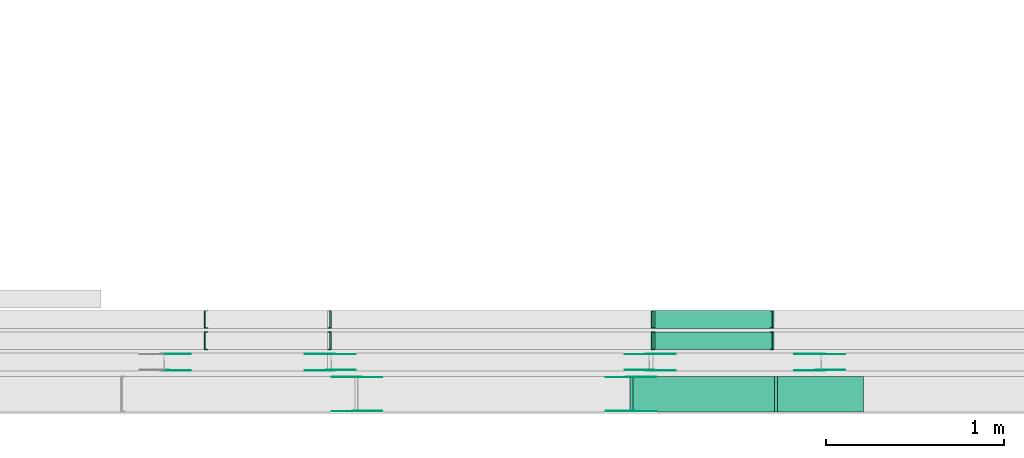
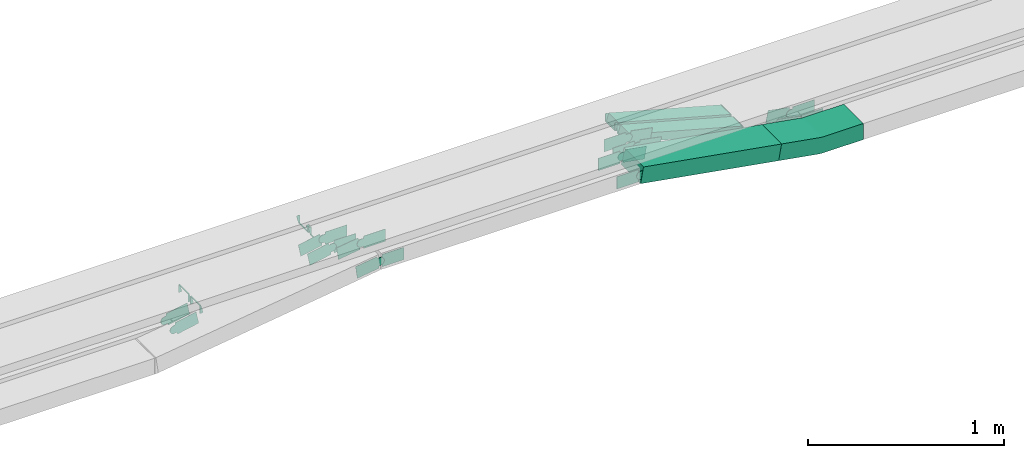
# One storey, part 8 of 28: 31 flow fittings, 3 flow segments.
"""IFC2X3 building model written with IfcOpenShell, lengths in millimetres."""

from ifc_helpers import new_model, entity, si_unit, converted_unit, derived_unit, direction, frame, frame_2d, origin, origin_2d_with_axis, place, context, subcontext, project, spatial, polyline, circle_curve, parameter, trimmed, segment, composite_curve, rectangle, outline, extrude, faceted_brep, source, transform, mapped, material, type_object, type_shapes, element, save


model = new_model("IFC2X3")

# Units and contexts
model_context = context("Model", 3, precision=0.01, world=origin(), true_north=direction((6.12303176911189e-17, 1.0)))
body_context = subcontext(model_context, "Body", "Model", "MODEL_VIEW")
ifc_project = project(units=[si_unit("LENGTHUNIT", "METRE", prefix="MILLI"), si_unit("AREAUNIT", "SQUARE_METRE"), si_unit("VOLUMEUNIT", "CUBIC_METRE"), converted_unit("PLANEANGLEUNIT", "DEGREE", entity("IfcRatioMeasure", 0.0174532925199433), si_unit("PLANEANGLEUNIT", "RADIAN"), dimensions=[0, 0, 0, 0, 0, 0, 0]), si_unit("MASSUNIT", "GRAM", prefix="KILO"), derived_unit("MASSDENSITYUNIT", [(si_unit("MASSUNIT", "GRAM", prefix="KILO"), 1), (si_unit("LENGTHUNIT", "METRE"), -3)]), derived_unit("MOMENTOFINERTIAUNIT", [(si_unit("LENGTHUNIT", "METRE"), 4)]), si_unit("TIMEUNIT", "SECOND"), si_unit("FREQUENCYUNIT", "HERTZ"), si_unit("THERMODYNAMICTEMPERATUREUNIT", "DEGREE_CELSIUS"), derived_unit("THERMALTRANSMITTANCEUNIT", [(si_unit("MASSUNIT", "GRAM", prefix="KILO"), 1), (si_unit("THERMODYNAMICTEMPERATUREUNIT", "KELVIN"), -1), (si_unit("TIMEUNIT", "SECOND"), -3)]), derived_unit("VOLUMETRICFLOWRATEUNIT", [(si_unit("LENGTHUNIT", "METRE"), 3), (si_unit("TIMEUNIT", "SECOND"), -1)]), derived_unit("MASSFLOWRATEUNIT", [(si_unit("MASSUNIT", "GRAM", prefix="KILO"), 1), (si_unit("TIMEUNIT", "SECOND"), -1)]), derived_unit("ROTATIONALFREQUENCYUNIT", [(si_unit("TIMEUNIT", "SECOND"), -1)]), si_unit("ELECTRICCURRENTUNIT", "AMPERE"), si_unit("ELECTRICVOLTAGEUNIT", "VOLT"), si_unit("POWERUNIT", "WATT"), si_unit("FORCEUNIT", "NEWTON", prefix="KILO"), si_unit("ILLUMINANCEUNIT", "LUX"), si_unit("LUMINOUSFLUXUNIT", "LUMEN"), si_unit("LUMINOUSINTENSITYUNIT", "CANDELA"), derived_unit("USERDEFINED", [(si_unit("MASSUNIT", "GRAM", prefix="KILO"), -1), (si_unit("LENGTHUNIT", "METRE"), -2), (si_unit("TIMEUNIT", "SECOND"), 3), (si_unit("LUMINOUSFLUXUNIT", "LUMEN"), 1)]), derived_unit("LINEARVELOCITYUNIT", [(si_unit("LENGTHUNIT", "METRE"), 1), (si_unit("TIMEUNIT", "SECOND"), -1)]), si_unit("PRESSUREUNIT", "PASCAL"), derived_unit("USERDEFINED", [(si_unit("LENGTHUNIT", "METRE"), -2), (si_unit("MASSUNIT", "GRAM", prefix="KILO"), 1), (si_unit("TIMEUNIT", "SECOND"), -2)]), derived_unit("LINEARFORCEUNIT", [(si_unit("MASSUNIT", "GRAM", prefix="KILO"), 1), (si_unit("LENGTHUNIT", "METRE"), 1), (si_unit("TIMEUNIT", "SECOND"), -2), (si_unit("LENGTHUNIT", "METRE"), -1)]), derived_unit("PLANARFORCEUNIT", [(si_unit("MASSUNIT", "GRAM", prefix="KILO"), 1), (si_unit("LENGTHUNIT", "METRE"), 1), (si_unit("TIMEUNIT", "SECOND"), -2), (si_unit("LENGTHUNIT", "METRE"), -2)])], contexts=[model_context])

# Site, building, storey
site_placement = place(None, origin())
site = spatial("IfcSite", under=ifc_project, at=site_placement, CompositionType="ELEMENT")
building_placement = place(site_placement, origin())
building = spatial("IfcBuilding", under=site, at=building_placement, CompositionType="ELEMENT")
storey_placement = place(building_placement, frame((0.0, 0.0, 15900.0)))
storey = spatial("IfcBuildingStorey", under=building, at=storey_placement, CompositionType="ELEMENT", Elevation=15900.0)

# Flow segments
cable_carrier_segment_type = type_object("IfcCableCarrierSegmentType", PredefinedType="CABLETRAYSEGMENT")
flow_segment_1_placement = place(storey_placement, frame((26335.74, 8695.5, 2502.67)))
element("IfcFlowSegment", 1, at=flow_segment_1_placement, inside=storey, type_object=cable_carrier_segment_type, context=body_context, shape_type="SweptSolid", body=[
    extrude(rectangle(XDim=50.0000000000012, YDim=99.9999999999989, at=frame_2d((0.0, 0.0), x_axis=(0.0, 1.0))), frame((6.61, 50.0, 205.56), z_axis=(0.964454896083655, 0.0, -0.264247523016331), x_axis=(0.0, 1.0, 0.0)), (0.0, 0.0, 1.0), 686.649727260089),
])
flow_segment_2_placement = place(storey_placement, frame((26335.74, 8575.5, 2502.67)))
element("IfcFlowSegment", 2, at=flow_segment_2_placement, inside=storey, type_object=cable_carrier_segment_type, context=body_context, shape_type="SweptSolid", body=[
    extrude(rectangle(XDim=50.0000000000012, YDim=100.000000000001, at=frame_2d((0.0, 0.0), x_axis=(0.0, 1.0))), frame((6.61, 50.0, 205.56), z_axis=(0.964454896083655, 0.0, -0.264247523016331), x_axis=(0.0, 1.0, 0.0)), (0.0, 0.0, 1.0), 686.649727260089),
])
flow_segment_3_placement = place(storey_placement, frame((26209.47, 8224.97, 2543.15)))
element("IfcFlowSegment", 3, at=flow_segment_3_placement, inside=storey, type_object=cable_carrier_segment_type, context=body_context, shape_type="SweptSolid", body=[
    extrude(rectangle(XDim=100.000000000002, YDim=200.0, at=origin_2d_with_axis()), frame((8.57, 100.0, 190.88), z_axis=(0.985213386101388, 0.0, -0.171331794616871), x_axis=(0.171331794616871, 0.0, 0.985213386101388)), (0.0, 0.0, 1.0), 826.568924613313),
])

# Flow fittings
ifc_material_1 = material()
cable_carrier_fitting_type_1 = type_object("IfcCableCarrierFittingType", PredefinedType="NOTDEFINED", material=ifc_material_1)
shared_shape_1 = source(origin(), body_context, "Body", "Brep", [
    faceted_brep([(-6.48, 25.0, 50.0), (-6.48, 25.0, -50.0), (-6.48, -25.0, -50.0), (-6.48, -25.0, -47.46), (-6.48, 22.46, -47.46), (-6.48, 22.46, 47.46), (-6.48, -25.0, 47.46), (-6.48, -25.0, 50.0), (-0.11, 25.83, 50.0), (12.65, -22.52, 50.0), (12.65, -22.52, 47.46), (0.54, 23.37, 47.46), (0.54, 23.37, -47.46), (12.65, -22.52, -47.46), (12.65, -22.52, -50.0), (-0.11, 25.83, -50.0), (-3.24, 25.0, 50.0), (-3.24, 25.0, -50.0), (3.24, -25.0, -50.0), (3.24, -25.0, -47.46), (-2.91, 22.46, -47.46), (-2.91, 22.46, 47.46), (3.24, -25.0, 47.46), (3.24, -25.0, 50.0)], [[[0, 1, 2, 3, 4, 5, 6, 7]], [[8, 9, 10, 11, 12, 13, 14, 15]], [[1, 0, 16, 17]], [[2, 1, 17, 15, 14, 18]], [[3, 2, 18, 19]], [[4, 3, 19, 13, 12, 20]], [[5, 4, 20, 21]], [[6, 5, 21, 11, 10, 22]], [[7, 6, 22, 23]], [[0, 7, 23, 9, 8, 16]], [[17, 16, 8, 15]], [[19, 18, 14, 13]], [[21, 20, 12, 11]], [[23, 22, 10, 9]]]),
])
type_shapes(cable_carrier_fitting_type_1, [shared_shape_1])
for number, where, z_axis, x_axis in (
    (4, (24519.76, 8745.5, 2710.0), (0.0, -1.0, 0.0), (-1.0, 0.0, 0.0)),
    (5, (24519.76, 8625.5, 2710.0), (0.0, -1.0, 0.0), (-1.0, 0.0, 0.0)),
    (6, (23818.49, 8625.5, 2525.0), (0.0, 1.0, 0.0), (-0.966919867770264, 0.0, -0.255080319333216)),
):
    element("IfcFlowFitting", number, at=place(storey_placement, frame(where, z_axis=z_axis, x_axis=x_axis)), inside=storey, type_object=cable_carrier_fitting_type_1, material=ifc_material_1, context=body_context, shape_type="MappedRepresentation", body=[
        mapped(shared_shape_1, transform((0.0, 0.0, 0.0), scale=1.0)),
    ])
cable_carrier_fitting_type_2 = type_object("IfcCableCarrierFittingType", PredefinedType="NOTDEFINED", material=ifc_material_1)
type_shapes(cable_carrier_fitting_type_2, [shared_shape_1])
flow_fitting_1_placement = place(storey_placement, frame((23818.49, 8745.5, 2525.0), z_axis=(0.0, 1.0, 0.0), x_axis=(-0.966919867770264, 0.0, -0.255080319333216)))
element("IfcFlowFitting", 7, at=flow_fitting_1_placement, inside=storey, type_object=cable_carrier_fitting_type_2, material=ifc_material_1, context=body_context, shape_type="MappedRepresentation", body=[
    mapped(shared_shape_1, transform((0.0, 0.0, 0.0), scale=1.0)),
])
cable_carrier_fitting_type_3 = type_object("IfcCableCarrierFittingType", PredefinedType="NOTDEFINED", material=ifc_material_1)
shared_shape_2 = source(origin(), body_context, "Body", "Brep", [
    faceted_brep([(-6.73, 25.0, 50.0), (-6.73, 25.0, -50.0), (-6.73, -25.0, -50.0), (-6.73, -25.0, -47.46), (-6.73, 22.46, -47.46), (-6.73, 22.46, 47.46), (-6.73, -25.0, 47.46), (-6.73, -25.0, 50.0), (-0.12, 25.89, 50.0), (13.09, -22.33, 50.0), (13.09, -22.33, 47.46), (0.55, 23.44, 47.46), (0.55, 23.44, -47.46), (13.09, -22.33, -47.46), (13.09, -22.33, -50.0), (-0.12, 25.89, -50.0), (-3.36, 25.0, 50.0), (-3.36, 25.0, -50.0), (3.36, -25.0, -50.0), (3.36, -25.0, -47.46), (-3.02, 22.46, -47.46), (-3.02, 22.46, 47.46), (3.36, -25.0, 47.46), (3.36, -25.0, 50.0)], [[[0, 1, 2, 3, 4, 5, 6, 7]], [[8, 9, 10, 11, 12, 13, 14, 15]], [[1, 0, 16, 17]], [[2, 1, 17, 15, 14, 18]], [[3, 2, 18, 19]], [[4, 3, 19, 13, 12, 20]], [[5, 4, 20, 21]], [[6, 5, 21, 11, 10, 22]], [[7, 6, 22, 23]], [[0, 7, 23, 9, 8, 16]], [[17, 16, 8, 15]], [[19, 18, 14, 13]], [[21, 20, 12, 11]], [[23, 22, 10, 9]]]),
])
type_shapes(cable_carrier_fitting_type_3, [shared_shape_2])
for number, where, z_axis, x_axis in (
    (8, (26335.86, 8745.5, 2710.0), (0.0, 1.0, 0.0), (1.0, 0.0, 0.0)),
    (9, (26335.86, 8625.5, 2710.0), (0.0, 1.0, 0.0), (1.0, 0.0, 0.0)),
    (10, (27011.08, 8745.5, 2525.0), (0.0, -1.0, 0.0), (0.964454896083642, 0.0, -0.264247523016377)),
    (11, (27011.08, 8625.5, 2525.0), (0.0, -1.0, 0.0), (0.964454896083642, 0.0, -0.264247523016377)),
):
    element("IfcFlowFitting", number, at=place(storey_placement, frame(where, z_axis=z_axis, x_axis=x_axis)), inside=storey, type_object=cable_carrier_fitting_type_3, material=ifc_material_1, context=body_context, shape_type="MappedRepresentation", body=[
        mapped(shared_shape_2, transform((0.0, 0.0, 0.0), scale=1.0)),
    ])
cable_carrier_fitting_type_4 = type_object("IfcCableCarrierFittingType", Name="470_DKC_S5_CS 90 internal vertical angle:-", PredefinedType="NOTDEFINED", material=ifc_material_1)
shared_shape_3 = source(origin(), body_context, "Body", "SweptSolid", [
    extrude(outline(composite_curve([segment(polyline([(-246.58, -61.21), (-13.27, -61.21)]), True, "CONTINUOUS"), segment(trimmed(circle_curve(frame_2d((-13.27, 153.79), x_axis=(0.0, -1.0)), 214.999999999999), [parameter(0.0)], [parameter(9.86526143430176)], True, "PARAMETER"), True, "CONTINUOUS"), segment(polyline([(23.56, -58.03), (253.42, -18.06)]), True, "CONTINUOUS"), segment(polyline([(253.42, -18.06), (236.29, 80.46)]), True, "CONTINUOUS"), segment(polyline([(236.29, 80.46), (6.43, 40.49)]), True, "CONTINUOUS"), segment(trimmed(circle_curve(frame_2d((-13.27, 153.79), x_axis=(0.0, -1.0)), 114.999999999999), [parameter(0.0)], [parameter(9.86526143430176)], True, "PARAMETER"), False, "CONTINUOUS"), segment(polyline([(-13.27, 38.79), (-246.58, 38.79)]), True, "CONTINUOUS"), segment(polyline([(-246.58, 38.79), (-246.58, -61.21)]), True, "CONTINUOUS")], self_intersect=False)), frame((-0.97, 11.21, -100.0)), (0.0, 0.0, 1.0), 200.0),
])
type_shapes(cable_carrier_fitting_type_4, [shared_shape_3])
flow_fitting_2_placement = place(storey_placement, frame((27276.27, 8324.97, 2550.0), z_axis=(0.0, 1.0, 0.0), x_axis=(-1.0, 0.0, 0.0)))
element("IfcFlowFitting", 12, at=flow_fitting_2_placement, inside=storey, type_object=cable_carrier_fitting_type_4, material=ifc_material_1, Name="470_DKC_S5_CS 90 internal vertical angle:-", ObjectType="470_DKC_S5_CS 90 internal vertical angle:-", context=body_context, shape_type="MappedRepresentation", body=[
    mapped(shared_shape_3, transform((0.0, 0.0, 0.0), scale=1.0)),
])
ifc_material_2 = material(Name="G")
cable_carrier_fitting_type_5 = type_object("IfcCableCarrierFittingType", PredefinedType="NOTDEFINED", material=ifc_material_2)
shared_shape_4 = source(origin(), body_context, "Body", "SweptSolid", [
    extrude(outline(composite_curve([segment(trimmed(circle_curve(frame_2d((-41.47, 0.0), x_axis=(1.0, 0.0)), 25.0), [parameter(90.0000000000007)], [parameter(270.0)], True, "PARAMETER"), True, "CONTINUOUS"), segment(polyline([(-41.47, -25.0), (-29.97, -25.0)]), True, "CONTINUOUS"), segment(polyline([(-29.97, -25.0), (-28.1, -38.5)]), True, "CONTINUOUS"), segment(polyline([(-28.1, -38.5), (99.53, -38.5)]), True, "CONTINUOUS"), segment(polyline([(99.53, -38.5), (99.53, 38.5)]), True, "CONTINUOUS"), segment(polyline([(99.53, 38.5), (-28.1, 38.5)]), True, "CONTINUOUS"), segment(polyline([(-28.1, 38.5), (-29.97, 25.0)]), True, "CONTINUOUS"), segment(polyline([(-29.97, 25.0), (-41.47, 25.0)]), True, "CONTINUOUS")], self_intersect=False)), frame((41.47, 0.0, 0.0), z_axis=(0.0, 0.0, -1.0), x_axis=(1.0, 0.0, 0.0)), (0.0, 0.0, -1.0), 2.0),
])
type_shapes(cable_carrier_fitting_type_5, [shared_shape_4])
flow_fitting_3_placement = place(storey_placement, frame((24523.32, 8459.51, 2735.0), z_axis=(0.0, -1.0, 0.0), x_axis=(-0.98087376548856, 0.0, -0.194644949013054)))
element("IfcFlowFitting", 13, at=flow_fitting_3_placement, inside=storey, type_object=cable_carrier_fitting_type_5, material=ifc_material_2, context=body_context, shape_type="MappedRepresentation", body=[
    mapped(shared_shape_4, transform((0.0, 0.0, 0.0), scale=1.0)),
])
cable_carrier_fitting_type_6 = type_object("IfcCableCarrierFittingType", PredefinedType="NOTDEFINED", material=ifc_material_2)
type_shapes(cable_carrier_fitting_type_6, [shared_shape_4])
flow_fitting_4_placement = place(storey_placement, frame((24523.32, 8548.43, 2735.0), z_axis=(0.0, 1.0, 0.0), x_axis=(1.0, 0.0, 0.0)))
element("IfcFlowFitting", 14, at=flow_fitting_4_placement, inside=storey, type_object=cable_carrier_fitting_type_6, material=ifc_material_2, context=body_context, shape_type="MappedRepresentation", body=[
    mapped(shared_shape_4, transform((0.0, 0.0, 0.0), scale=1.0)),
])
flow_fitting_5_placement = place(storey_placement, frame((26322.05, 8550.43, 2735.0), z_axis=(0.0, 1.0, 0.0), x_axis=(0.981897917883986, 0.0, -0.189410873117392)))
element("IfcFlowFitting", 15, at=flow_fitting_5_placement, inside=storey, type_object=cable_carrier_fitting_type_5, material=ifc_material_2, context=body_context, shape_type="MappedRepresentation", body=[
    mapped(shared_shape_4, transform((0.0, 0.0, 0.0), scale=1.0)),
])
flow_fitting_6_placement = place(storey_placement, frame((26322.05, 8461.51, 2735.0), z_axis=(0.0, -1.0, 0.0), x_axis=(-1.0, 0.0, 0.0)))
element("IfcFlowFitting", 16, at=flow_fitting_6_placement, inside=storey, type_object=cable_carrier_fitting_type_6, material=ifc_material_2, context=body_context, shape_type="MappedRepresentation", body=[
    mapped(shared_shape_4, transform((0.0, 0.0, 0.0), scale=1.0)),
])
for number, where, z_axis, x_axis in (
    (17, (23591.05, 8459.51, 2550.0), (0.0, -1.0, 0.0), (0.98087376548856, 0.0, 0.194644949013054)),
    (18, (27281.08, 8550.43, 2550.0), (0.0, 1.0, 0.0), (-0.981897917883986, 0.0, 0.189410873117392)),
):
    element("IfcFlowFitting", number, at=place(storey_placement, frame(where, z_axis=z_axis, x_axis=x_axis)), inside=storey, type_object=cable_carrier_fitting_type_5, material=ifc_material_2, context=body_context, shape_type="MappedRepresentation", body=[
        mapped(shared_shape_4, transform((0.0, 0.0, 0.0), scale=1.0)),
    ])
flow_fitting_7_placement = place(storey_placement, frame((27281.08, 8461.51, 2550.0), z_axis=(0.0, -1.0, 0.0), x_axis=(1.0, 0.0, 0.0)))
element("IfcFlowFitting", 19, at=flow_fitting_7_placement, inside=storey, type_object=cable_carrier_fitting_type_6, material=ifc_material_2, context=body_context, shape_type="MappedRepresentation", body=[
    mapped(shared_shape_4, transform((0.0, 0.0, 0.0), scale=1.0)),
])
flow_fitting_8_placement = place(storey_placement, frame((24673.73, 8229.51, 2735.0), z_axis=(0.0, -1.0, 0.0), x_axis=(-0.990375964698788, 0.0, -0.138403210031213)))
element("IfcFlowFitting", 20, at=flow_fitting_8_placement, inside=storey, type_object=cable_carrier_fitting_type_5, material=ifc_material_2, context=body_context, shape_type="MappedRepresentation", body=[
    mapped(shared_shape_4, transform((0.0, 0.0, 0.0), scale=1.0)),
])
flow_fitting_9_placement = place(storey_placement, frame((24673.73, 8418.43, 2735.0), z_axis=(0.0, 1.0, 0.0), x_axis=(1.0, 0.0, 0.0)))
element("IfcFlowFitting", 21, at=flow_fitting_9_placement, inside=storey, type_object=cable_carrier_fitting_type_6, material=ifc_material_2, context=body_context, shape_type="MappedRepresentation", body=[
    mapped(shared_shape_4, transform((0.0, 0.0, 0.0), scale=1.0)),
])
flow_fitting_10_placement = place(storey_placement, frame((26212.46, 8420.43, 2735.0), z_axis=(0.0, 1.0, 0.0), x_axis=(0.985213386101383, 0.0, -0.171331794616902)))
element("IfcFlowFitting", 22, at=flow_fitting_10_placement, inside=storey, type_object=cable_carrier_fitting_type_5, material=ifc_material_2, context=body_context, shape_type="MappedRepresentation", body=[
    mapped(shared_shape_4, transform((0.0, 0.0, 0.0), scale=1.0)),
])
flow_fitting_11_placement = place(storey_placement, frame((26212.46, 8231.51, 2735.0), z_axis=(0.0, -1.0, 0.0), x_axis=(-1.0, 0.0, 0.0)))
element("IfcFlowFitting", 23, at=flow_fitting_11_placement, inside=storey, type_object=cable_carrier_fitting_type_6, material=ifc_material_2, context=body_context, shape_type="MappedRepresentation", body=[
    mapped(shared_shape_4, transform((0.0, 0.0, 0.0), scale=1.0)),
])
cable_carrier_fitting_type_7 = type_object("IfcCableCarrierFittingType", PredefinedType="NOTDEFINED", material=ifc_material_2)
shared_shape_5 = source(origin(), body_context, "Body", "SweptSolid", [
    extrude(outline(composite_curve([segment(trimmed(circle_curve(frame_2d((-41.47, 0.0), x_axis=(1.0, 0.0)), 25.0), [parameter(90.0000000000007)], [parameter(270.0)], True, "PARAMETER"), True, "CONTINUOUS"), segment(polyline([(-41.47, -25.0), (-29.97, -25.0)]), True, "CONTINUOUS"), segment(polyline([(-29.97, -25.0), (-28.1, -38.5)]), True, "CONTINUOUS"), segment(polyline([(-28.1, -38.5), (99.53, -38.5)]), True, "CONTINUOUS"), segment(polyline([(99.53, -38.5), (99.53, 38.5)]), True, "CONTINUOUS"), segment(polyline([(99.53, 38.5), (-28.1, 38.5)]), True, "CONTINUOUS"), segment(polyline([(-28.1, 38.5), (-29.97, 25.0)]), True, "CONTINUOUS"), segment(polyline([(-29.97, 25.0), (-41.47, 25.0)]), True, "CONTINUOUS")], self_intersect=False)), frame((41.47, 0.0, 0.0)), (0.0, 0.0, 1.0), 2.0),
])
type_shapes(cable_carrier_fitting_type_7, [shared_shape_5])
flow_fitting_12_placement = place(storey_placement, frame((24523.32, 8550.43, 2735.0), z_axis=(0.0, 1.0, 0.0), x_axis=(-0.98087376548856, 0.0, -0.194644949013054)))
element("IfcFlowFitting", 24, at=flow_fitting_12_placement, inside=storey, type_object=cable_carrier_fitting_type_7, material=ifc_material_2, context=body_context, shape_type="MappedRepresentation", body=[
    mapped(shared_shape_5, transform((0.0, 0.0, 0.0), scale=1.0)),
])
cable_carrier_fitting_type_8 = type_object("IfcCableCarrierFittingType", PredefinedType="NOTDEFINED", material=ifc_material_2)
type_shapes(cable_carrier_fitting_type_8, [shared_shape_5])
flow_fitting_13_placement = place(storey_placement, frame((24523.32, 8461.51, 2735.0), z_axis=(0.0, -1.0, 0.0), x_axis=(1.0, 0.0, 0.0)))
element("IfcFlowFitting", 25, at=flow_fitting_13_placement, inside=storey, type_object=cable_carrier_fitting_type_8, material=ifc_material_2, context=body_context, shape_type="MappedRepresentation", body=[
    mapped(shared_shape_5, transform((0.0, 0.0, 0.0), scale=1.0)),
])
flow_fitting_14_placement = place(storey_placement, frame((26322.05, 8459.51, 2735.0), z_axis=(0.0, -1.0, 0.0), x_axis=(0.981897917883986, 0.0, -0.189410873117392)))
element("IfcFlowFitting", 26, at=flow_fitting_14_placement, inside=storey, type_object=cable_carrier_fitting_type_7, material=ifc_material_2, context=body_context, shape_type="MappedRepresentation", body=[
    mapped(shared_shape_5, transform((0.0, 0.0, 0.0), scale=1.0)),
])
flow_fitting_15_placement = place(storey_placement, frame((26322.05, 8548.43, 2735.0), z_axis=(0.0, 1.0, 0.0), x_axis=(-1.0, 0.0, 0.0)))
element("IfcFlowFitting", 27, at=flow_fitting_15_placement, inside=storey, type_object=cable_carrier_fitting_type_8, material=ifc_material_2, context=body_context, shape_type="MappedRepresentation", body=[
    mapped(shared_shape_5, transform((0.0, 0.0, 0.0), scale=1.0)),
])
for number, where, z_axis, x_axis in (
    (28, (23591.05, 8550.43, 2550.0), (0.0, 1.0, 0.0), (0.98087376548856, 0.0, 0.194644949013054)),
    (29, (27281.08, 8459.51, 2550.0), (0.0, -1.0, 0.0), (-0.981897917883986, 0.0, 0.189410873117392)),
):
    element("IfcFlowFitting", number, at=place(storey_placement, frame(where, z_axis=z_axis, x_axis=x_axis)), inside=storey, type_object=cable_carrier_fitting_type_7, material=ifc_material_2, context=body_context, shape_type="MappedRepresentation", body=[
        mapped(shared_shape_5, transform((0.0, 0.0, 0.0), scale=1.0)),
    ])
flow_fitting_16_placement = place(storey_placement, frame((27281.08, 8548.43, 2550.0), z_axis=(0.0, 1.0, 0.0), x_axis=(1.0, 0.0, 0.0)))
element("IfcFlowFitting", 30, at=flow_fitting_16_placement, inside=storey, type_object=cable_carrier_fitting_type_8, material=ifc_material_2, context=body_context, shape_type="MappedRepresentation", body=[
    mapped(shared_shape_5, transform((0.0, 0.0, 0.0), scale=1.0)),
])
flow_fitting_17_placement = place(storey_placement, frame((24673.73, 8420.43, 2735.0), z_axis=(0.0, 1.0, 0.0), x_axis=(-0.990375964698788, 0.0, -0.138403210031213)))
element("IfcFlowFitting", 31, at=flow_fitting_17_placement, inside=storey, type_object=cable_carrier_fitting_type_7, material=ifc_material_2, context=body_context, shape_type="MappedRepresentation", body=[
    mapped(shared_shape_5, transform((0.0, 0.0, 0.0), scale=1.0)),
])
flow_fitting_18_placement = place(storey_placement, frame((24673.73, 8231.51, 2735.0), z_axis=(0.0, -1.0, 0.0), x_axis=(1.0, 0.0, 0.0)))
element("IfcFlowFitting", 32, at=flow_fitting_18_placement, inside=storey, type_object=cable_carrier_fitting_type_8, material=ifc_material_2, context=body_context, shape_type="MappedRepresentation", body=[
    mapped(shared_shape_5, transform((0.0, 0.0, 0.0), scale=1.0)),
])
flow_fitting_19_placement = place(storey_placement, frame((26212.46, 8229.51, 2735.0), z_axis=(0.0, -1.0, 0.0), x_axis=(0.985213386101383, 0.0, -0.171331794616902)))
element("IfcFlowFitting", 33, at=flow_fitting_19_placement, inside=storey, type_object=cable_carrier_fitting_type_7, material=ifc_material_2, context=body_context, shape_type="MappedRepresentation", body=[
    mapped(shared_shape_5, transform((0.0, 0.0, 0.0), scale=1.0)),
])
flow_fitting_20_placement = place(storey_placement, frame((26212.46, 8418.43, 2735.0), z_axis=(0.0, 1.0, 0.0), x_axis=(-1.0, 0.0, 0.0)))
element("IfcFlowFitting", 34, at=flow_fitting_20_placement, inside=storey, type_object=cable_carrier_fitting_type_8, material=ifc_material_2, context=body_context, shape_type="MappedRepresentation", body=[
    mapped(shared_shape_5, transform((0.0, 0.0, 0.0), scale=1.0)),
])

save(model, "model.ifc")
